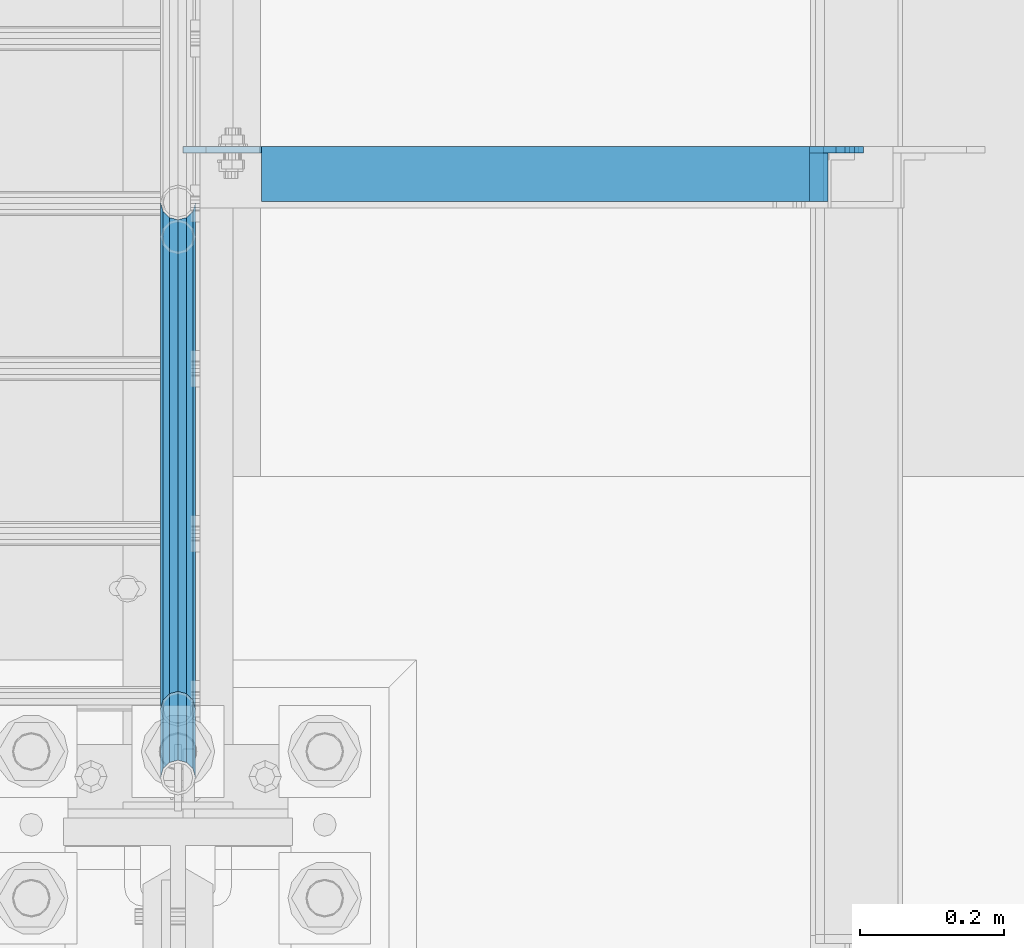
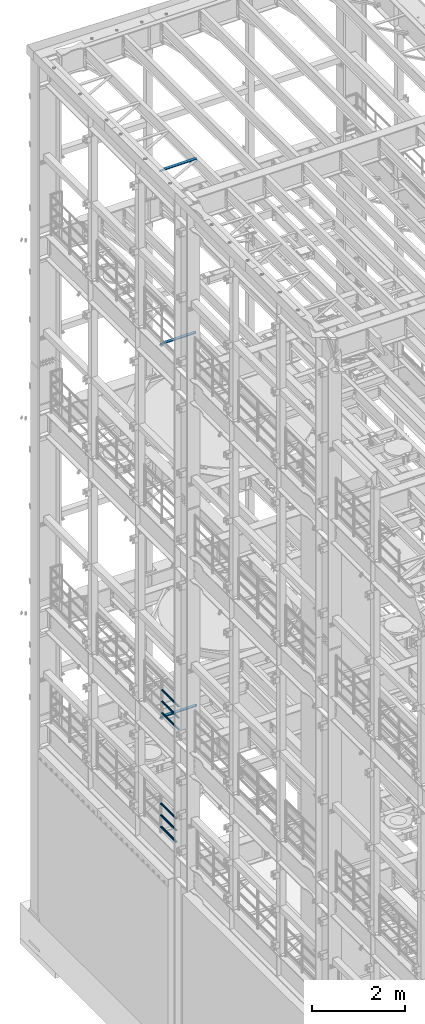
# One storey, part 1293 of 1876: 9 beams, 5 elements without a shape of their own.
"""IFC2X3 building model written with IfcOpenShell, lengths in millimetres."""

from ifc_helpers import new_model, si_unit, frame, origin_with_axes, place, context, subcontext, project, spatial, faceted_brep, material, type_object, element, aggregate, save


model = new_model("IFC2X3")

# Units and contexts
model_context = context("Model", 3, precision=1e-05, world=origin_with_axes())
body_context = subcontext(model_context, "Body", "Model", "MODEL_VIEW")
ifc_project = project(units=[si_unit("LENGTHUNIT", "METRE", prefix="MILLI"), si_unit("AREAUNIT", "SQUARE_METRE"), si_unit("VOLUMEUNIT", "CUBIC_METRE"), si_unit("MASSUNIT", "GRAM", prefix="KILO"), si_unit("TIMEUNIT", "SECOND"), si_unit("PLANEANGLEUNIT", "RADIAN"), si_unit("SOLIDANGLEUNIT", "STERADIAN"), si_unit("THERMODYNAMICTEMPERATUREUNIT", "DEGREE_CELSIUS"), si_unit("LUMINOUSINTENSITYUNIT", "LUMEN")], contexts=[model_context])

# Site, building, storey
site_placement = place(None, origin_with_axes())
site = spatial("IfcSite", under=ifc_project, at=site_placement, CompositionType="ELEMENT")
building_placement = place(site_placement, origin_with_axes())
building = spatial("IfcBuilding", under=site, at=building_placement, Name="Undefined", CompositionType="ELEMENT")
storey_placement = place(building_placement, origin_with_axes())
storey = spatial("IfcBuildingStorey", under=building, at=storey_placement, Name="Undefined", CompositionType="ELEMENT", Elevation=0.0)

# Assembly, beams
assembly_1_placement = place(storey_placement, origin_with_axes())
assembly_1 = element("IfcElementAssembly", 1, at=assembly_1_placement, inside=storey, Name="RAIL", AssemblyPlace="NOTDEFINED", PredefinedType="RIGID_FRAME")
ifc_material_1 = material()
beam_type_1 = type_object("IfcBeamType", Name="PIPE1-1/2SCH40", PredefinedType="NOTDEFINED")
beam_1_placement = place(assembly_1_placement, frame((-1.81898940354586e-12, 8713.7875, 8315.325), z_axis=(0.0, 0.0, 1.0), x_axis=(0.0, -1.0, 0.0)))
beam_1 = element("IfcBeam", 2, at=beam_1_placement, type_object=beam_type_1, material=ifc_material_1, Name="RAIL", ObjectType="PIPE1-1/2SCH40", context=body_context, shape_type="Brep", body=[
    faceted_brep([(728.085307006683, -12.0649999999996, 20.8971929933177), (728.085307006683, -12.0649999999996, 15.8661214311796), (727.591878568821, -10.2235000000001, 17.7076214311819), (724.852500000002, 0.0, 20.4470000000001), (724.852500000002, 0.0, 24.130000000001), (727.591878568821, 10.2235000000001, 17.7076214311819), (728.085307006683, 12.0649999999996, 15.8661214311796), (728.085307006683, 12.0649999999996, 20.8971929933177), (748.982500000002, 24.1300000000001, 0.0), (736.917500000002, 20.8971929933186, 12.0649999999987), (736.917500000002, 20.8971929933186, -12.0649999999987), (733.727928437864, 17.7076214311801, 10.2235000000001), (736.467307006683, 20.4470000000001, 0.0), (733.727928437864, 17.7076214311801, -10.2235000000001), (728.085307006683, 12.0649999999996, -15.8661214311796), (728.085307006683, 12.0649999999996, -20.8971929933177), (727.591878568821, 10.2235000000001, -17.7076214311819), (724.852500000002, 0.0, -20.4470000000001), (724.852500000002, 0.0, -24.130000000001), (728.085307006683, -12.0649999999996, -15.8661214311796), (728.085307006683, -12.0649999999996, -20.8971929933177), (727.591878568821, -10.2235000000001, -17.7076214311819), (748.982500000002, -24.1300000000001, 0.0), (736.917500000002, -20.8971929933186, -12.0649999999987), (736.917500000002, -20.8971929933186, 12.0649999999987), (733.727928437864, -17.7076214311801, -10.2235000000001), (736.467307006683, -20.4470000000001, 0.0), (733.727928437864, -17.7076214311801, 10.2235000000001), (12.0650000000064, -20.8971929933177, -12.0649999999987), (20.8971929933249, -12.0650000000005, -20.8971929933177), (0.0, 24.1299999999992, 0.0), (12.0650000000064, 20.8971929933177, -12.0649999999987), (12.0650000000064, 20.8971929933177, 12.0649999999987), (20.8971929933249, 12.0650000000005, 20.8971929933177), (24.1300000000064, 0.0, 24.130000000001), (20.8971929933249, 12.0650000000005, -20.8971929933177), (24.1300000000063, 0.0, -24.130000000001), (24.1300000000063, 0.0, -20.4470000000001), (20.8971929933249, -12.0650000000005, -15.8661214311796), (21.3906214311868, -10.2235000000001, -17.7076214311819), (21.3906214311868, 10.2235000000001, -17.7076214311819), (20.8971929933249, 12.0650000000005, -15.8661214311796), (15.2545715621445, 17.7076214311801, -10.2235000000001), (12.5151929933249, 20.4470000000001, 0.0), (15.2545715621445, 17.7076214311801, 10.2235000000001), (20.8971929933249, 12.0650000000005, 15.8661214311796), (21.3906214311868, 10.2235000000001, 17.7076214311819), (24.1300000000064, 0.0, 20.4470000000001), (21.3906214311868, -10.2235000000001, 17.7076214311819), (20.8971929933249, -12.0650000000005, 15.8661214311796), (20.8971929933249, -12.0650000000005, 20.8971929933177), (12.0650000000064, -20.8971929933177, 12.0649999999987), (0.0, -24.1299999999992, 0.0), (15.2545715621445, -17.7076214311801, 10.2235000000001), (12.5151929933249, -20.4470000000001, 0.0), (15.2545715621445, -17.7076214311801, -10.2235000000001)], [[[0, 1, 2, 3, 4]], [[4, 3, 5, 6, 7]], [[8, 9, 10]], [[7, 6, 11, 12, 13, 14, 15, 10, 9]], [[16, 17, 18, 15, 14]], [[19, 20, 18, 17, 21]], [[22, 23, 24]], [[24, 23, 20, 19, 25, 26, 27, 1, 0]], [[28, 29, 20, 23]], [[30, 31, 32]], [[33, 34, 4, 7]], [[32, 33, 7, 9]], [[30, 32, 9, 8]], [[31, 30, 8, 10]], [[35, 31, 10, 15]], [[36, 35, 15, 18]], [[29, 36, 18, 20]], [[37, 36, 29, 38, 39]], [[40, 41, 35, 36, 37]], [[32, 31, 35, 41, 42, 43, 44, 45, 33]], [[33, 45, 46, 47, 34]], [[34, 47, 48, 49, 50]], [[34, 50, 0, 4]], [[50, 51, 24, 0]], [[51, 52, 22, 24]], [[52, 28, 23, 22]], [[51, 28, 52]], [[50, 49, 53, 54, 55, 38, 29, 28, 51]], [[55, 54, 26, 25]], [[21, 39, 38, 55, 25, 19]], [[37, 39, 21, 17]], [[40, 37, 17, 16]], [[42, 41, 40, 16, 14, 13]], [[43, 42, 13, 12]], [[44, 43, 12, 11]], [[5, 46, 45, 44, 11, 6]], [[47, 46, 5, 3]], [[48, 47, 3, 2]], [[53, 49, 48, 2, 1, 27]], [[54, 53, 27, 26]]]),
])
beam_2_placement = place(assembly_1_placement, frame((-1.81898940354586e-12, 7964.805, 8620.125), z_axis=(0.0, 0.0, -1.0), x_axis=(0.0, 1.0, 0.0)))
beam_2 = element("IfcBeam", 3, at=beam_2_placement, type_object=beam_type_1, material=ifc_material_1, Name="RAIL", ObjectType="PIPE1-1/2SCH40", context=body_context, shape_type="Brep", body=[
    faceted_brep([(0.0, 24.1299999999992, 0.0), (12.0650000000064, 20.8971929933177, -12.0649999999987), (12.0650000000064, 20.8971929933177, 12.0649999999987), (12.0650000000064, -20.8971929933177, 12.0649999999987), (12.0650000000064, -20.8971929933177, -12.0649999999987), (0.0, -24.1299999999992, 0.0), (20.8971929933249, -12.0650000000005, 20.8971929933177), (20.8971929933249, -12.0650000000005, 15.8661214311796), (15.2545715621445, -17.7076214311801, 10.2235000000001), (12.5151929933249, -20.4470000000001, 0.0), (15.2545715621445, -17.7076214311801, -10.2235000000001), (20.8971929933249, -12.0650000000005, -15.8661214311796), (20.8971929933249, -12.0650000000005, -20.8971929933177), (24.1300000000063, 0.0, -20.4470000000001), (24.1300000000063, 0.0, -24.130000000001), (21.3906214311868, -10.2235000000001, -17.7076214311819), (21.3906214311868, 10.2235000000001, -17.7076214311819), (20.8971929933249, 12.0650000000005, -15.8661214311796), (20.8971929933249, 12.0650000000005, -20.8971929933177), (15.2545715621445, 17.7076214311801, -10.2235000000001), (12.5151929933249, 20.4470000000001, 0.0), (15.2545715621445, 17.7076214311801, 10.2235000000001), (20.8971929933249, 12.0650000000005, 15.8661214311796), (20.8971929933249, 12.0650000000005, 20.8971929933177), (21.3906214311868, 10.2235000000001, 17.7076214311819), (24.1300000000064, 0.0, 20.4470000000001), (24.1300000000064, 0.0, 24.130000000001), (21.3906214311868, -10.2235000000001, 17.7076214311819), (748.982500000002, 24.1300000000001, 0.0), (736.917500000002, 20.8971929933186, -12.0649999999987), (728.085307006683, 12.0649999999996, -20.8971929933177), (748.982500000002, -24.1300000000001, 0.0), (736.917500000002, -20.8971929933186, -12.0649999999987), (736.917500000002, -20.8971929933186, 12.0649999999987), (728.085307006683, -12.0649999999996, 20.8971929933177), (728.085307006683, -12.0649999999996, -20.8971929933177), (724.852500000002, 0.0, -24.130000000001), (727.591878568821, 10.2235000000001, -17.7076214311819), (724.852500000002, 0.0, -20.4470000000001), (728.085307006683, 12.0649999999996, -15.8661214311796), (728.085307006683, -12.0649999999996, -15.8661214311796), (727.591878568821, -10.2235000000001, -17.7076214311819), (733.727928437864, -17.7076214311801, -10.2235000000001), (736.467307006683, -20.4470000000001, 0.0), (733.727928437864, -17.7076214311801, 10.2235000000001), (728.085307006683, -12.0649999999996, 15.8661214311796), (727.591878568821, -10.2235000000001, 17.7076214311819), (724.852500000002, 0.0, 20.4470000000001), (724.852500000002, 0.0, 24.130000000001), (728.085307006683, 12.0649999999996, 20.8971929933177), (736.917500000002, 20.8971929933186, 12.0649999999987), (728.085307006683, 12.0649999999996, 15.8661214311796), (733.727928437864, 17.7076214311801, 10.2235000000001), (736.467307006683, 20.4470000000001, 0.0), (733.727928437864, 17.7076214311801, -10.2235000000001), (727.591878568821, 10.2235000000001, 17.7076214311819)], [[[0, 1, 2]], [[3, 4, 5]], [[6, 7, 8, 9, 10, 11, 12, 4, 3]], [[13, 14, 12, 11, 15]], [[16, 17, 18, 14, 13]], [[2, 1, 18, 17, 19, 20, 21, 22, 23]], [[23, 22, 24, 25, 26]], [[26, 25, 27, 7, 6]], [[1, 0, 28, 29]], [[18, 1, 29, 30]], [[31, 32, 33]], [[6, 3, 33, 34]], [[3, 5, 31, 33]], [[5, 4, 32, 31]], [[4, 12, 35, 32]], [[12, 14, 36, 35]], [[14, 18, 30, 36]], [[37, 38, 36, 30, 39]], [[40, 35, 36, 38, 41]], [[33, 32, 35, 40, 42, 43, 44, 45, 34]], [[34, 45, 46, 47, 48]], [[26, 6, 34, 48]], [[2, 23, 49, 50]], [[23, 26, 48, 49]], [[0, 2, 50, 28]], [[28, 50, 29]], [[49, 51, 52, 53, 54, 39, 30, 29, 50]], [[48, 47, 55, 51, 49]], [[25, 24, 55, 47]], [[55, 24, 22, 21, 52, 51]], [[21, 20, 53, 52]], [[20, 19, 54, 53]], [[19, 17, 16, 37, 39, 54]], [[16, 13, 38, 37]], [[13, 15, 41, 38]], [[41, 15, 11, 10, 42, 40]], [[10, 9, 43, 42]], [[9, 8, 44, 43]], [[8, 7, 27, 46, 45, 44]], [[27, 25, 47, 46]]]),
])
beam_3_placement = place(assembly_1_placement, frame((-1.81898940354586e-12, 7964.805, 8924.925), z_axis=(0.0, 0.0, -1.0), x_axis=(0.0, 1.0, 0.0)))
beam_3 = element("IfcBeam", 4, at=beam_3_placement, type_object=beam_type_1, material=ifc_material_1, Name="RAIL", ObjectType="PIPE1-1/2SCH40", context=body_context, shape_type="Brep", body=[
    faceted_brep([(0.0, 24.1299999999992, 0.0), (12.0650000000064, 20.8971929933177, -12.0649999999987), (12.0650000000064, 20.8971929933177, 12.0649999999987), (12.0650000000064, -20.8971929933177, 12.0649999999987), (12.0650000000064, -20.8971929933177, -12.0649999999987), (0.0, -24.1299999999992, 0.0), (20.8971929933249, -12.0650000000005, 20.8971929933177), (20.8971929933249, -12.0650000000005, 15.8661214311796), (15.2545715621445, -17.7076214311801, 10.2235000000001), (12.5151929933249, -20.4470000000001, 0.0), (15.2545715621445, -17.7076214311801, -10.2235000000001), (20.8971929933249, -12.0650000000005, -15.8661214311796), (20.8971929933249, -12.0650000000005, -20.8971929933177), (24.1300000000063, 0.0, -20.4470000000001), (24.1300000000063, 0.0, -24.130000000001), (21.3906214311868, -10.2235000000001, -17.7076214311819), (21.3906214311868, 10.2235000000001, -17.7076214311819), (20.8971929933249, 12.0650000000005, -15.8661214311796), (20.8971929933249, 12.0650000000005, -20.8971929933177), (15.2545715621445, 17.7076214311801, -10.2235000000001), (12.5151929933249, 20.4470000000001, 0.0), (15.2545715621445, 17.7076214311801, 10.2235000000001), (20.8971929933249, 12.0650000000005, 15.8661214311796), (20.8971929933249, 12.0650000000005, 20.8971929933177), (21.3906214311868, 10.2235000000001, 17.7076214311819), (24.1300000000064, 0.0, 20.4470000000001), (24.1300000000064, 0.0, 24.130000000001), (21.3906214311868, -10.2235000000001, 17.7076214311819), (748.982500000002, 24.1300000000001, 0.0), (736.917500000002, 20.8971929933186, -12.0649999999987), (728.085307006683, 12.0649999999996, -20.8971929933177), (748.982500000002, -24.1300000000001, 0.0), (736.917500000002, -20.8971929933186, -12.0649999999987), (736.917500000002, -20.8971929933186, 12.0649999999987), (728.085307006683, -12.0649999999996, 20.8971929933177), (728.085307006683, -12.0649999999996, -20.8971929933177), (724.852500000002, 0.0, -24.130000000001), (727.591878568821, 10.2235000000001, -17.7076214311819), (724.852500000002, 0.0, -20.4470000000001), (728.085307006683, 12.0649999999996, -15.8661214311796), (728.085307006683, -12.0649999999996, -15.8661214311796), (727.591878568821, -10.2235000000001, -17.7076214311819), (733.727928437864, -17.7076214311801, -10.2235000000001), (736.467307006683, -20.4470000000001, 0.0), (733.727928437864, -17.7076214311801, 10.2235000000001), (728.085307006683, -12.0649999999996, 15.8661214311796), (727.591878568821, -10.2235000000001, 17.7076214311819), (724.852500000002, 0.0, 20.4470000000001), (724.852500000002, 0.0, 24.130000000001), (728.085307006683, 12.0649999999996, 20.8971929933177), (736.917500000002, 20.8971929933186, 12.0649999999987), (728.085307006683, 12.0649999999996, 15.8661214311796), (733.727928437864, 17.7076214311801, 10.2235000000001), (736.467307006683, 20.4470000000001, 0.0), (733.727928437864, 17.7076214311801, -10.2235000000001), (727.591878568821, 10.2235000000001, 17.7076214311819)], [[[0, 1, 2]], [[3, 4, 5]], [[6, 7, 8, 9, 10, 11, 12, 4, 3]], [[13, 14, 12, 11, 15]], [[16, 17, 18, 14, 13]], [[2, 1, 18, 17, 19, 20, 21, 22, 23]], [[23, 22, 24, 25, 26]], [[26, 25, 27, 7, 6]], [[1, 0, 28, 29]], [[18, 1, 29, 30]], [[31, 32, 33]], [[6, 3, 33, 34]], [[3, 5, 31, 33]], [[5, 4, 32, 31]], [[4, 12, 35, 32]], [[12, 14, 36, 35]], [[14, 18, 30, 36]], [[37, 38, 36, 30, 39]], [[40, 35, 36, 38, 41]], [[33, 32, 35, 40, 42, 43, 44, 45, 34]], [[34, 45, 46, 47, 48]], [[26, 6, 34, 48]], [[2, 23, 49, 50]], [[23, 26, 48, 49]], [[0, 2, 50, 28]], [[28, 50, 29]], [[49, 51, 52, 53, 54, 39, 30, 29, 50]], [[48, 47, 55, 51, 49]], [[25, 24, 55, 47]], [[55, 24, 22, 21, 52, 51]], [[21, 20, 53, 52]], [[20, 19, 54, 53]], [[19, 17, 16, 37, 39, 54]], [[16, 13, 38, 37]], [[13, 15, 41, 38]], [[41, 15, 11, 10, 42, 40]], [[10, 9, 43, 42]], [[9, 8, 44, 43]], [[8, 7, 27, 46, 45, 44]], [[27, 25, 47, 46]]]),
])
aggregate(assembly_1, [beam_1, beam_2, beam_3])

assembly_2_placement = place(storey_placement, origin_with_axes())
assembly_2 = element("IfcElementAssembly", 5, at=assembly_2_placement, inside=storey, Name="RAIL", AssemblyPlace="NOTDEFINED", PredefinedType="RIGID_FRAME")
beam_4_placement = place(assembly_2_placement, frame((-1.81898940354586e-12, 8761.4125, 5292.725), z_axis=(0.0, 0.0, 1.0), x_axis=(0.0, -1.0, 0.0)))
beam_4 = element("IfcBeam", 6, at=beam_4_placement, type_object=beam_type_1, material=ifc_material_1, Name="RAIL", ObjectType="PIPE1-1/2SCH40", context=body_context, shape_type="Brep", body=[
    faceted_brep([(680.460307006681, -12.0649999999996, 20.8971929933186), (680.460307006681, -12.0649999999914, 15.8661214311887), (679.966878568822, -10.2235000000001, 17.7076214311801), (677.2275, 0.0, 20.4470000000001), (677.2275, 0.0, 24.1300000000001), (679.966878568817, 10.2235000000001, 17.7076214311801), (680.460307006681, 12.0650000000078, 15.8661214311724), (680.460307006681, 12.0649999999996, 20.8971929933186), (701.3575, 24.1300000000001, 0.0), (689.2925, 20.8971929933186, 12.0649999999996), (689.2925, 20.8971929933186, -12.0649999999996), (686.102928437854, 17.7076214311801, 10.2235000000001), (688.842307006673, 20.4470000000001, 0.0), (686.102928437854, 17.7076214311801, -10.2235000000001), (680.460307006681, 12.0650000000078, -15.8661214311724), (680.460307006681, 12.0649999999996, -20.8971929933186), (679.966878568817, 10.2235000000001, -17.7076214311801), (677.2275, 0.0, -20.4470000000001), (677.2275, 0.0, -24.1300000000001), (680.460307006681, -12.0649999999914, -15.8661214311887), (680.460307006681, -12.0649999999996, -20.8971929933186), (679.966878568822, -10.2235000000001, -17.7076214311801), (701.3575, -24.1299999999919, 0.0), (689.2925, -20.8971929933186, -12.0649999999996), (689.2925, -20.8971929933186, 12.0649999999996), (686.10292843787, -17.7076214311801, -10.2235000000001), (688.842307006689, -20.4470000000001, 0.0), (686.10292843787, -17.7076214311801, 10.2235000000001), (12.0650000000064, -20.8971929933177, -12.0649999999987), (20.8971929933249, -12.0650000000005, -20.8971929933177), (0.0, 24.1299999999992, 0.0), (12.0650000000064, 20.8971929933177, -12.0649999999987), (12.0650000000064, 20.8971929933177, 12.0649999999987), (20.8971929933249, 12.0650000000005, 20.8971929933177), (24.1300000000064, 0.0, 24.130000000001), (20.8971929933249, 12.0650000000005, -20.8971929933177), (24.1300000000063, 0.0, -24.130000000001), (24.1300000000063, 0.0, -20.4470000000001), (20.8971929933249, -12.0650000000005, -15.8661214311796), (21.3906214311868, -10.2235000000001, -17.7076214311819), (21.3906214311868, 10.2235000000001, -17.7076214311819), (20.8971929933249, 12.0650000000005, -15.8661214311796), (15.2545715621445, 17.7076214311801, -10.2235000000001), (12.5151929933249, 20.4470000000001, 0.0), (15.2545715621445, 17.7076214311801, 10.2235000000001), (20.8971929933249, 12.0650000000005, 15.8661214311796), (21.3906214311868, 10.2235000000001, 17.7076214311819), (24.1300000000064, 0.0, 20.4470000000001), (21.3906214311868, -10.2235000000001, 17.7076214311819), (20.8971929933249, -12.0650000000005, 15.8661214311796), (20.8971929933249, -12.0650000000005, 20.8971929933177), (12.0650000000064, -20.8971929933177, 12.0649999999987), (0.0, -24.1299999999992, 0.0), (15.2545715621445, -17.7076214311801, 10.2235000000001), (12.5151929933249, -20.4470000000001, 0.0), (15.2545715621445, -17.7076214311801, -10.2235000000001)], [[[0, 1, 2, 3, 4]], [[4, 3, 5, 6, 7]], [[8, 9, 10]], [[7, 6, 11, 12, 13, 14, 15, 10, 9]], [[16, 17, 18, 15, 14]], [[19, 20, 18, 17, 21]], [[22, 23, 24]], [[24, 23, 20, 19, 25, 26, 27, 1, 0]], [[28, 29, 20, 23]], [[30, 31, 32]], [[33, 34, 4, 7]], [[32, 33, 7, 9]], [[30, 32, 9, 8]], [[31, 30, 8, 10]], [[35, 31, 10, 15]], [[36, 35, 15, 18]], [[29, 36, 18, 20]], [[37, 36, 29, 38, 39]], [[40, 41, 35, 36, 37]], [[32, 31, 35, 41, 42, 43, 44, 45, 33]], [[33, 45, 46, 47, 34]], [[34, 47, 48, 49, 50]], [[34, 50, 0, 4]], [[50, 51, 24, 0]], [[51, 52, 22, 24]], [[52, 28, 23, 22]], [[51, 28, 52]], [[50, 49, 53, 54, 55, 38, 29, 28, 51]], [[55, 54, 26, 25]], [[21, 39, 38, 55, 25, 19]], [[37, 39, 21, 17]], [[40, 37, 17, 16]], [[42, 41, 40, 16, 14, 13]], [[43, 42, 13, 12]], [[44, 43, 12, 11]], [[5, 46, 45, 44, 11, 6]], [[47, 46, 5, 3]], [[48, 47, 3, 2]], [[53, 49, 48, 2, 1, 27]], [[54, 53, 27, 26]]]),
])
beam_5_placement = place(assembly_2_placement, frame((-1.81898940354586e-12, 8060.055, 5597.525), z_axis=(0.0, 0.0, -1.0), x_axis=(0.0, 1.0, 0.0)))
beam_5 = element("IfcBeam", 7, at=beam_5_placement, type_object=beam_type_1, material=ifc_material_1, Name="RAIL", ObjectType="PIPE1-1/2SCH40", context=body_context, shape_type="Brep", body=[
    faceted_brep([(0.0, 24.1299999999992, 0.0), (12.0650000000064, 20.8971929933177, -12.0649999999987), (12.0650000000064, 20.8971929933177, 12.0649999999987), (12.0650000000064, -20.8971929933177, 12.0649999999987), (12.0650000000064, -20.8971929933177, -12.0649999999987), (0.0, -24.1299999999992, 0.0), (20.8971929933249, -12.0650000000005, 20.8971929933177), (20.8971929933249, -12.0650000000005, 15.8661214311796), (15.2545715621445, -17.7076214311801, 10.2235000000001), (12.5151929933249, -20.4470000000001, 0.0), (15.2545715621445, -17.7076214311801, -10.2235000000001), (20.8971929933249, -12.0650000000005, -15.8661214311796), (20.8971929933249, -12.0650000000005, -20.8971929933177), (24.1300000000063, 0.0, -20.4470000000001), (24.1300000000063, 0.0, -24.130000000001), (21.3906214311868, -10.2235000000001, -17.7076214311819), (21.3906214311868, 10.2235000000001, -17.7076214311819), (20.8971929933249, 12.0650000000005, -15.8661214311796), (20.8971929933249, 12.0650000000005, -20.8971929933177), (15.2545715621445, 17.7076214311801, -10.2235000000001), (12.5151929933249, 20.4470000000001, 0.0), (15.2545715621445, 17.7076214311801, 10.2235000000001), (20.8971929933249, 12.0650000000005, 15.8661214311796), (20.8971929933249, 12.0650000000005, 20.8971929933177), (21.3906214311868, 10.2235000000001, 17.7076214311819), (24.1300000000064, 0.0, 20.4470000000001), (24.1300000000064, 0.0, 24.130000000001), (21.3906214311868, -10.2235000000001, 17.7076214311819), (701.3575, 24.1300000000001, 0.0), (689.2925, 20.8971929933186, -12.0649999999996), (680.460307006681, 12.0649999999996, -20.8971929933186), (701.3575, -24.1299999999919, 0.0), (689.2925, -20.8971929933186, -12.0649999999996), (689.2925, -20.8971929933186, 12.0649999999996), (680.460307006681, -12.0649999999996, 20.8971929933186), (680.460307006681, -12.0649999999996, -20.8971929933186), (677.2275, 0.0, -24.1300000000001), (679.966878568817, 10.2235000000001, -17.7076214311801), (677.2275, 0.0, -20.4470000000001), (680.460307006681, 12.0650000000078, -15.8661214311724), (680.460307006681, -12.0649999999914, -15.8661214311887), (679.966878568822, -10.2235000000001, -17.7076214311801), (686.10292843787, -17.7076214311801, -10.2235000000001), (688.842307006689, -20.4470000000001, 0.0), (686.10292843787, -17.7076214311801, 10.2235000000001), (680.460307006681, -12.0649999999914, 15.8661214311887), (679.966878568822, -10.2235000000001, 17.7076214311801), (677.2275, 0.0, 20.4470000000001), (677.2275, 0.0, 24.1300000000001), (680.460307006681, 12.0649999999996, 20.8971929933186), (689.2925, 20.8971929933186, 12.0649999999996), (680.460307006681, 12.0650000000078, 15.8661214311724), (686.102928437854, 17.7076214311801, 10.2235000000001), (688.842307006673, 20.4470000000001, 0.0), (686.102928437854, 17.7076214311801, -10.2235000000001), (679.966878568817, 10.2235000000001, 17.7076214311801)], [[[0, 1, 2]], [[3, 4, 5]], [[6, 7, 8, 9, 10, 11, 12, 4, 3]], [[13, 14, 12, 11, 15]], [[16, 17, 18, 14, 13]], [[2, 1, 18, 17, 19, 20, 21, 22, 23]], [[23, 22, 24, 25, 26]], [[26, 25, 27, 7, 6]], [[1, 0, 28, 29]], [[18, 1, 29, 30]], [[31, 32, 33]], [[6, 3, 33, 34]], [[3, 5, 31, 33]], [[5, 4, 32, 31]], [[4, 12, 35, 32]], [[12, 14, 36, 35]], [[14, 18, 30, 36]], [[37, 38, 36, 30, 39]], [[40, 35, 36, 38, 41]], [[33, 32, 35, 40, 42, 43, 44, 45, 34]], [[34, 45, 46, 47, 48]], [[26, 6, 34, 48]], [[2, 23, 49, 50]], [[23, 26, 48, 49]], [[0, 2, 50, 28]], [[28, 50, 29]], [[49, 51, 52, 53, 54, 39, 30, 29, 50]], [[48, 47, 55, 51, 49]], [[25, 24, 55, 47]], [[55, 24, 22, 21, 52, 51]], [[21, 20, 53, 52]], [[20, 19, 54, 53]], [[19, 17, 16, 37, 39, 54]], [[16, 13, 38, 37]], [[13, 15, 41, 38]], [[41, 15, 11, 10, 42, 40]], [[10, 9, 43, 42]], [[9, 8, 44, 43]], [[8, 7, 27, 46, 45, 44]], [[27, 25, 47, 46]]]),
])
beam_6_placement = place(assembly_2_placement, frame((-1.81898940354586e-12, 8060.055, 5902.325), z_axis=(0.0, 0.0, -1.0), x_axis=(0.0, 1.0, 0.0)))
beam_6 = element("IfcBeam", 8, at=beam_6_placement, type_object=beam_type_1, material=ifc_material_1, Name="RAIL", ObjectType="PIPE1-1/2SCH40", context=body_context, shape_type="Brep", body=[
    faceted_brep([(0.0, 24.1299999999992, 0.0), (12.0650000000064, 20.8971929933177, -12.0649999999987), (12.0650000000064, 20.8971929933177, 12.0649999999987), (12.0650000000064, -20.8971929933177, 12.0649999999987), (12.0650000000064, -20.8971929933177, -12.0649999999987), (0.0, -24.1299999999992, 0.0), (20.8971929933249, -12.0650000000005, 20.8971929933177), (20.8971929933249, -12.0650000000005, 15.8661214311796), (15.2545715621445, -17.7076214311801, 10.2235000000001), (12.5151929933249, -20.4470000000001, 0.0), (15.2545715621445, -17.7076214311801, -10.2235000000001), (20.8971929933249, -12.0650000000005, -15.8661214311796), (20.8971929933249, -12.0650000000005, -20.8971929933177), (24.1300000000063, 0.0, -20.4470000000001), (24.1300000000063, 0.0, -24.130000000001), (21.3906214311868, -10.2235000000001, -17.7076214311819), (21.3906214311868, 10.2235000000001, -17.7076214311819), (20.8971929933249, 12.0650000000005, -15.8661214311796), (20.8971929933249, 12.0650000000005, -20.8971929933177), (15.2545715621445, 17.7076214311801, -10.2235000000001), (12.5151929933249, 20.4470000000001, 0.0), (15.2545715621445, 17.7076214311801, 10.2235000000001), (20.8971929933249, 12.0650000000005, 15.8661214311796), (20.8971929933249, 12.0650000000005, 20.8971929933177), (21.3906214311868, 10.2235000000001, 17.7076214311819), (24.1300000000064, 0.0, 20.4470000000001), (24.1300000000064, 0.0, 24.130000000001), (21.3906214311868, -10.2235000000001, 17.7076214311819), (701.3575, 24.1300000000001, 0.0), (689.2925, 20.8971929933186, -12.0649999999996), (680.460307006681, 12.0649999999996, -20.8971929933186), (701.3575, -24.1299999999919, 0.0), (689.2925, -20.8971929933186, -12.0649999999996), (689.2925, -20.8971929933186, 12.0649999999996), (680.460307006681, -12.0649999999996, 20.8971929933186), (680.460307006681, -12.0649999999996, -20.8971929933186), (677.2275, 0.0, -24.1300000000001), (679.966878568817, 10.2235000000001, -17.7076214311801), (677.2275, 0.0, -20.4470000000001), (680.460307006681, 12.0650000000078, -15.8661214311724), (680.460307006681, -12.0649999999914, -15.8661214311887), (679.966878568822, -10.2235000000001, -17.7076214311801), (686.10292843787, -17.7076214311801, -10.2235000000001), (688.842307006689, -20.4470000000001, 0.0), (686.10292843787, -17.7076214311801, 10.2235000000001), (680.460307006681, -12.0649999999914, 15.8661214311887), (679.966878568822, -10.2235000000001, 17.7076214311801), (677.2275, 0.0, 20.4470000000001), (677.2275, 0.0, 24.1300000000001), (680.460307006681, 12.0649999999996, 20.8971929933186), (689.2925, 20.8971929933186, 12.0649999999996), (680.460307006681, 12.0650000000078, 15.8661214311724), (686.102928437854, 17.7076214311801, 10.2235000000001), (688.842307006673, 20.4470000000001, 0.0), (686.102928437854, 17.7076214311801, -10.2235000000001), (679.966878568817, 10.2235000000001, 17.7076214311801)], [[[0, 1, 2]], [[3, 4, 5]], [[6, 7, 8, 9, 10, 11, 12, 4, 3]], [[13, 14, 12, 11, 15]], [[16, 17, 18, 14, 13]], [[2, 1, 18, 17, 19, 20, 21, 22, 23]], [[23, 22, 24, 25, 26]], [[26, 25, 27, 7, 6]], [[1, 0, 28, 29]], [[18, 1, 29, 30]], [[31, 32, 33]], [[6, 3, 33, 34]], [[3, 5, 31, 33]], [[5, 4, 32, 31]], [[4, 12, 35, 32]], [[12, 14, 36, 35]], [[14, 18, 30, 36]], [[37, 38, 36, 30, 39]], [[40, 35, 36, 38, 41]], [[33, 32, 35, 40, 42, 43, 44, 45, 34]], [[34, 45, 46, 47, 48]], [[26, 6, 34, 48]], [[2, 23, 49, 50]], [[23, 26, 48, 49]], [[0, 2, 50, 28]], [[28, 50, 29]], [[49, 51, 52, 53, 54, 39, 30, 29, 50]], [[48, 47, 55, 51, 49]], [[25, 24, 55, 47]], [[55, 24, 22, 21, 52, 51]], [[21, 20, 53, 52]], [[20, 19, 54, 53]], [[19, 17, 16, 37, 39, 54]], [[16, 13, 38, 37]], [[13, 15, 41, 38]], [[41, 15, 11, 10, 42, 40]], [[10, 9, 43, 42]], [[9, 8, 44, 43]], [[8, 7, 27, 46, 45, 44]], [[27, 25, 47, 46]]]),
])
aggregate(assembly_2, [beam_4, beam_5, beam_6])

# Assembly, beam
assembly_3_placement = place(storey_placement, origin_with_axes())
assembly_3 = element("IfcElementAssembly", 9, at=assembly_3_placement, inside=storey, Name="ANGLE", AssemblyPlace="NOTDEFINED", PredefinedType="RIGID_FRAME")
ifc_material_2 = material(Name="STEEL/A36")
beam_type_2 = type_object("IfcBeamType", Name="L3X3X3/8", PredefinedType="NOTDEFINED")
beam_7_placement = place(assembly_3_placement, frame((4.51516825708356e-09, 8801.1, 22517.1), z_axis=(0.0, -1.0, 0.0), x_axis=(1.0, 0.0, 0.0)))
beam_7 = element("IfcBeam", 10, at=beam_7_placement, type_object=beam_type_2, material=ifc_material_2, Name="ANGLE", ObjectType="L3X3X3/8", context=body_context, shape_type="Brep", body=[
    faceted_brep([(115.886999817316, 28.5750000000007, 38.0999999999999), (115.886999817316, 38.0999999999985, 38.0999999999999), (115.886998826692, 38.0999999999985, -38.0999999999999), (115.88699882669, 12.699999237062, -38.0999999999999), (115.886998950515, 12.699999237062, -28.5749999999998), (115.88699895052, 28.5750000000007, -28.5749999999998), (38.8937432114558, 12.699999237062, -38.0999999999999), (38.8937433352807, 12.699999237062, -28.5749999999998), (7.14374321145577, -19.050000762938, -38.0999999999999), (7.14374333528067, -19.050000762938, -28.5749999999998), (7.1437499954859, -38.0999999999985, -38.0999999999999), (7.1437499954859, -38.0999999999985, -28.5749999999998), (949.325002419604, 15.8750003814712, -28.5749999999998), (936.625002610339, 28.5750000000007, -28.5749999999998), (900.113000619098, 28.5750000000007, -28.5749999999998), (949.324999995485, -38.0999999999985, -28.5749999999998), (949.325002419604, 3.17500152588036, -28.5749999999998), (900.11300241932, 28.5750000000007, 38.0999999999999), (900.1130024193, 38.0999999999985, 38.0999999999999), (900.113000361957, 38.0999999999985, -38.0999999999999), (900.113000361924, 28.5750001907363, -38.0999999999999), (936.625002353164, 28.5750001907363, -38.0999999999999), (949.325002162429, 15.8750003814712, -38.0999999999999), (949.325002162429, 3.17500152588036, -38.0999999999999), (949.324999995485, -38.0999999999985, -38.0999999999999)], [[[0, 1, 2, 3, 4, 5]], [[4, 3, 6, 7]], [[7, 6, 8, 9]], [[8, 10, 11, 9]], [[12, 13, 14, 5, 4, 7, 9, 11, 15, 16]], [[0, 5, 14, 17]], [[1, 0, 17, 18]], [[2, 1, 18, 19]], [[17, 14, 20, 19, 18]], [[13, 21, 20, 14]], [[12, 22, 21, 13]], [[16, 23, 22, 12]], [[10, 8, 6, 3, 2, 19, 20, 21, 22, 23, 24]], [[11, 10, 24, 15]], [[23, 16, 15, 24]]]),
])
aggregate(assembly_3, [beam_7])

assembly_4_placement = place(storey_placement, origin_with_axes())
assembly_4 = element("IfcElementAssembly", 11, at=assembly_4_placement, inside=storey, Name="ANGLE", AssemblyPlace="NOTDEFINED", PredefinedType="RIGID_FRAME")
beam_8_placement = place(assembly_4_placement, frame((2.91964701648869e-08, 8801.1, 17945.1), z_axis=(0.0, -1.0, 0.0), x_axis=(1.0, 0.0, 0.0)))
beam_8 = element("IfcBeam", 12, at=beam_8_placement, type_object=beam_type_2, material=ifc_material_2, Name="ANGLE", ObjectType="L3X3X3/8", context=body_context, shape_type="Brep", body=[
    faceted_brep([(115.886999817316, 28.5750000000007, 38.0999999999999), (115.886999817316, 38.0999999999985, 38.0999999999999), (115.886998826692, 38.0999999999985, -38.0999999999999), (115.88699882669, 12.699999237062, -38.0999999999999), (115.886998950515, 12.699999237062, -28.5749999999998), (115.88699895052, 28.5750000000007, -28.5749999999998), (38.8937432114558, 12.699999237062, -38.0999999999999), (38.8937433352807, 12.699999237062, -28.5749999999998), (7.14374321145577, -19.050000762938, -38.0999999999999), (7.14374333528067, -19.050000762938, -28.5749999999998), (7.1437499954859, -38.0999999999985, -38.0999999999999), (7.1437499954859, -38.0999999999985, -28.5749999999998), (923.925002394923, 15.8750003814748, -28.5750000000007), (911.225002585658, 28.5750000000007, -28.5750000000007), (874.713000594384, 28.5750000000007, -28.5750000000007), (923.924999986645, -38.0999999999985, -28.5750000000007), (923.925002394923, 3.175001525884, -28.5750000000007), (874.713002394605, 28.5750000000007, 38.1000000000004), (874.713002394611, 38.0999999999985, 38.1000000000004), (874.713000337267, 38.0999999999985, -38.1000000000004), (874.71300033721, 28.57500019074, -38.1000000000004), (911.225002328483, 28.57500019074, -38.1000000000004), (923.925002137748, 15.8750003814748, -38.1000000000004), (923.925002137748, 3.175001525884, -38.1000000000004), (923.924999986645, -38.0999999999985, -38.1000000000004)], [[[0, 1, 2, 3, 4, 5]], [[4, 3, 6, 7]], [[7, 6, 8, 9]], [[8, 10, 11, 9]], [[12, 13, 14, 5, 4, 7, 9, 11, 15, 16]], [[0, 5, 14, 17]], [[1, 0, 17, 18]], [[2, 1, 18, 19]], [[17, 14, 20, 19, 18]], [[13, 21, 20, 14]], [[12, 22, 21, 13]], [[16, 23, 22, 12]], [[10, 8, 6, 3, 2, 19, 20, 21, 22, 23, 24]], [[11, 10, 24, 15]], [[23, 16, 15, 24]]]),
])
aggregate(assembly_4, [beam_8])

assembly_5_placement = place(storey_placement, origin_with_axes())
assembly_5 = element("IfcElementAssembly", 13, at=assembly_5_placement, inside=storey, Name="ANGLE", AssemblyPlace="NOTDEFINED", PredefinedType="RIGID_FRAME")
beam_9_placement = place(assembly_5_placement, frame((4.54521503245139e-09, 8801.1, 8115.3), z_axis=(0.0, -1.0, 0.0), x_axis=(1.0, 0.0, 0.0)))
beam_9 = element("IfcBeam", 14, at=beam_9_placement, type_object=beam_type_2, material=ifc_material_2, Name="ANGLE", ObjectType="L3X3X3/8", context=body_context, shape_type="Brep", body=[
    faceted_brep([(115.886999817316, 28.5750000000007, 38.0999999999999), (115.886999817316, 38.0999999999985, 38.0999999999999), (115.886998826692, 38.0999999999985, -38.0999999999999), (115.88699882669, 12.699999237062, -38.0999999999999), (115.886998950515, 12.699999237062, -28.5749999999998), (115.88699895052, 28.5750000000007, -28.5749999999998), (38.8937432114558, 12.699999237062, -38.0999999999999), (38.8937433352807, 12.699999237062, -28.5749999999998), (7.14374321145577, -19.050000762938, -38.0999999999999), (7.14374333528067, -19.050000762938, -28.5749999999998), (7.1437499954859, -38.0999999999985, -38.0999999999999), (7.1437499954859, -38.0999999999985, -28.5749999999998), (942.975002419575, 15.8750003814703, -28.5750000000007), (930.27500261031, 28.5749999999998, -28.5750000000007), (893.763000619072, 28.5749999999998, -28.5750000000007), (942.974999995456, -38.1000000000004, -28.5750000000007), (942.975002419575, 3.17500152587945, -28.5750000000007), (893.763002419293, 28.5749999999998, 38.1000000000004), (893.763002419272, 38.1000000000004, 38.1000000000004), (893.763000361928, 38.1000000000004, -38.1000000000004), (893.763000361898, 28.5750001907354, -38.1000000000004), (930.275002353135, 28.5750001907354, -38.1000000000004), (942.9750021624, 15.8750003814703, -38.1000000000004), (942.9750021624, 3.17500152587945, -38.1000000000004), (942.974999995456, -38.1000000000004, -38.1000000000004)], [[[0, 1, 2, 3, 4, 5]], [[4, 3, 6, 7]], [[7, 6, 8, 9]], [[8, 10, 11, 9]], [[12, 13, 14, 5, 4, 7, 9, 11, 15, 16]], [[0, 5, 14, 17]], [[1, 0, 17, 18]], [[2, 1, 18, 19]], [[17, 14, 20, 19, 18]], [[13, 21, 20, 14]], [[12, 22, 21, 13]], [[16, 23, 22, 12]], [[10, 8, 6, 3, 2, 19, 20, 21, 22, 23, 24]], [[11, 10, 24, 15]], [[23, 16, 15, 24]]]),
])
aggregate(assembly_5, [beam_9])

save(model, "model.ifc")
